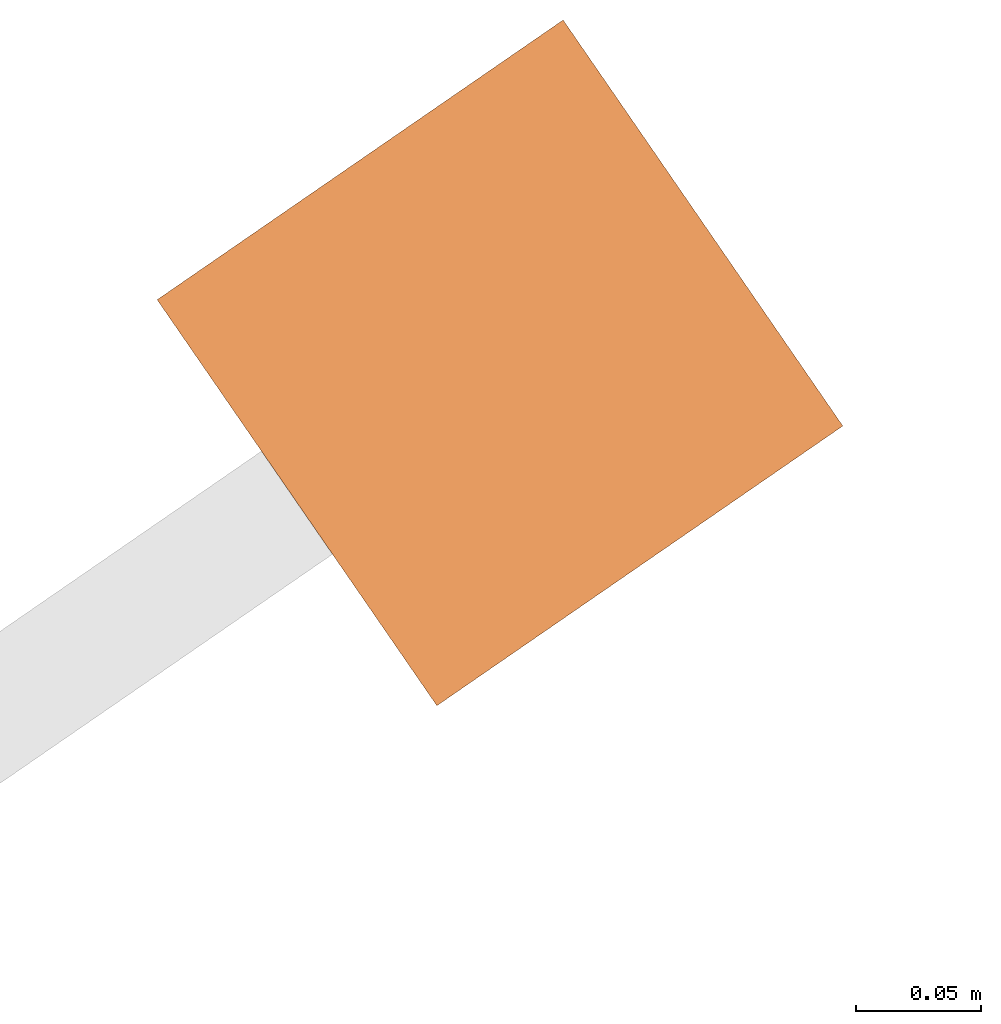
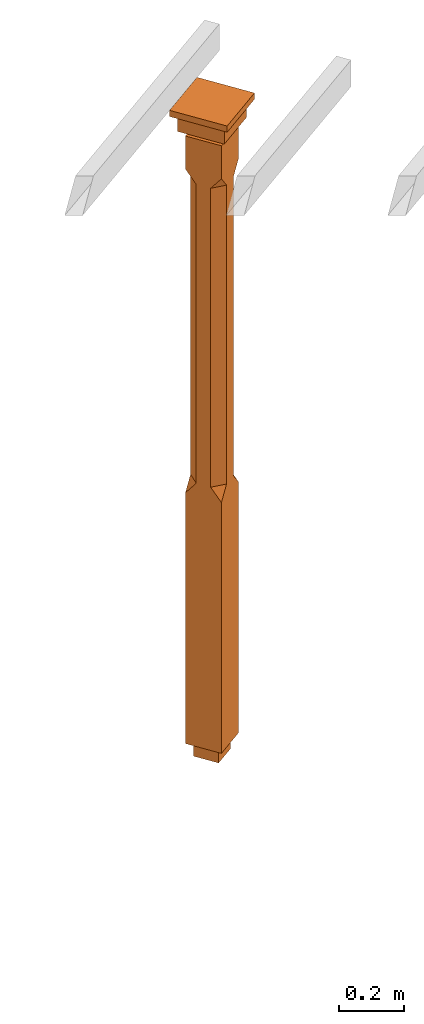
# One storey, part 12 of 12: 1 proxy.
"""IFC2X3 building model written with IfcOpenShell, lengths in metres."""

from ifc_helpers import new_model, si_unit, frame, origin, place, context, subcontext, project, spatial, faceted_brep, element, save


model = new_model("IFC2X3")

# Units and contexts
model_context = context("Model", 3, world=origin())
body_context = subcontext(model_context, "Body", "Model", "MODEL_VIEW")
ifc_project = project(units=[si_unit("PLANEANGLEUNIT", "RADIAN"), si_unit("MASSUNIT", "GRAM", prefix="KILO"), si_unit("FORCEUNIT", "NEWTON", prefix="KILO"), si_unit("LENGTHUNIT", "METRE")], contexts=[model_context])

# Site, building, storey
site_placement = place(None, origin())
site = spatial("IfcSite", under=ifc_project, at=site_placement, CompositionType="ELEMENT")
building_placement = place(None, origin())
building = spatial("IfcBuilding", under=site, at=building_placement, Name="Building plot-7", CompositionType="ELEMENT")
storey_placement = place(None, frame((0.0, 0.0, 8.0)))
storey = spatial("IfcBuildingStorey", under=building, at=storey_placement, Name="Floor 1", CompositionType="ELEMENT", Elevation=8.0)

# Proxy
proxy_placement = place(storey_placement, frame((88.1518638427974, 73.3891824818848, 0.0), z_axis=(0.0, 0.0, 1.0), x_axis=(-0.823462667604971, -0.567370456633851, 0.0)))
element("IfcBuildingElementProxy", 1, at=proxy_placement, inside=storey, Name="pergola post", CompositionType="ELEMENT", context=body_context, shape_type="Brep", held_by="IfcProductRepresentation", body=[
    faceted_brep([(0.0246, -0.0615, 2.17), (0.0615, -0.0246, 2.17), (0.0615, -0.0615, 2.216667), (0.0615, -0.0246, 1.044444), (0.0246, -0.0615, 1.044444), (0.0615, 0.0246, 2.17), (0.0615, 0.0615, 2.216667), (-0.0246, -0.0615, 2.17), (-0.0615, -0.0615, 2.216667), (-0.0246, -0.0615, 1.044444), (0.0615, -0.0615, 0.997778), (0.0615, 0.0246, 1.044444), (0.0246, 0.0615, 2.17), (0.0615, 0.0615, 2.341111), (0.0615, -0.0615, 2.341111), (-0.0615, -0.0615, 2.341111), (-0.0615, -0.0246, 2.17), (-0.0615, -0.0246, 1.044444), (-0.0615, -0.0615, 0.997778), (0.0615, 0.0615, 0.997778), (0.0246, 0.0615, 1.044444), (-0.0246, 0.0615, 2.17), (-0.0615, 0.0615, 2.216667), (0.04305, 0.04305, 2.341111), (0.04305, -0.04305, 2.341111), (-0.0615, 0.0615, 2.341111), (-0.04305, -0.04305, 2.341111), (-0.0615, 0.0246, 2.17), (-0.0615, 0.0246, 1.044444), (0.0615, -0.0615, 0.053333), (-0.0615, -0.0615, 0.053333), (0.0615, 0.0615, 0.053333), (-0.0246, 0.0615, 1.044444), (-0.04305, 0.04305, 2.341111), (0.04305, 0.04305, 2.364444), (0.04305, -0.04305, 2.364444), (-0.04305, -0.04305, 2.364444), (-0.0615, 0.0615, 0.997778), (-0.0615, 0.0615, 0.053333), (-0.04305, -0.04305, 0.053333), (0.04305, -0.04305, 0.053333), (0.04305, 0.04305, 0.053333), (-0.04305, 0.04305, 2.364444), (0.07995, 0.07995, 2.364444), (0.07995, -0.07995, 2.364444), (-0.07995, -0.07995, 2.364444), (-0.04305, 0.04305, 0.053333), (-0.04305, -0.04305, 0.0), (0.04305, -0.04305, 0.0), (0.04305, 0.04305, 0.0), (-0.07995, 0.07995, 2.364444), (0.07995, 0.07995, 2.426667), (0.07995, -0.07995, 2.426667), (-0.07995, -0.07995, 2.426667), (-0.04305, 0.04305, 0.0), (-0.07995, 0.07995, 2.426667), (0.0984, 0.0984, 2.426667), (0.0984, -0.0984, 2.426667), (-0.0984, -0.0984, 2.426667), (-0.0984, 0.0984, 2.426667), (0.0984, 0.0984, 2.45), (0.0984, -0.0984, 2.45), (-0.0984, -0.0984, 2.45), (-0.0984, 0.0984, 2.45)], [[[0, 1, 2]], [[3, 1, 0, 4]], [[1, 5, 6, 2]], [[7, 0, 2, 8]], [[4, 0, 7, 9]], [[3, 4, 10]], [[1, 3, 11, 5]], [[5, 12, 6]], [[13, 14, 2, 6]], [[15, 8, 2, 14]], [[8, 16, 7]], [[9, 7, 16, 17]], [[9, 18, 10, 4]], [[3, 10, 19, 11]], [[20, 12, 5, 11]], [[21, 22, 6, 12]], [[14, 13, 23, 24]], [[13, 6, 22, 25]], [[25, 22, 8, 15]], [[26, 15, 14, 24]], [[16, 8, 22, 27]], [[27, 28, 17, 16]], [[17, 18, 9]], [[29, 10, 18, 30]], [[31, 19, 10, 29]], [[20, 11, 19]], [[12, 20, 32, 21]], [[21, 27, 22]], [[33, 23, 13, 25]], [[23, 34, 35, 24]], [[26, 33, 25, 15]], [[36, 26, 24, 35]], [[28, 27, 21, 32]], [[17, 28, 37, 18]], [[38, 30, 18, 37]], [[29, 30, 39, 40]], [[31, 38, 37, 19]], [[40, 41, 31, 29]], [[32, 20, 19, 37]], [[33, 42, 34, 23]], [[43, 44, 35, 34]], [[42, 33, 26, 36]], [[36, 35, 44, 45]], [[28, 32, 37]], [[46, 39, 30, 38]], [[39, 47, 48, 40]], [[46, 38, 31, 41]], [[49, 41, 40, 48]], [[43, 34, 42, 50]], [[43, 51, 52, 44]], [[45, 50, 42, 36]], [[53, 45, 44, 52]], [[46, 54, 47, 39]], [[54, 46, 41, 49]], [[50, 55, 51, 43]], [[56, 57, 52, 51]], [[55, 50, 45, 53]], [[53, 52, 57, 58]], [[56, 51, 55, 59]], [[56, 60, 61, 57]], [[58, 59, 55, 53]], [[62, 58, 57, 61]], [[59, 63, 60, 56]], [[63, 62, 61, 60]], [[58, 62, 63, 59]], [[47, 54, 49, 48]]]),
])

save(model, "model.ifc")
